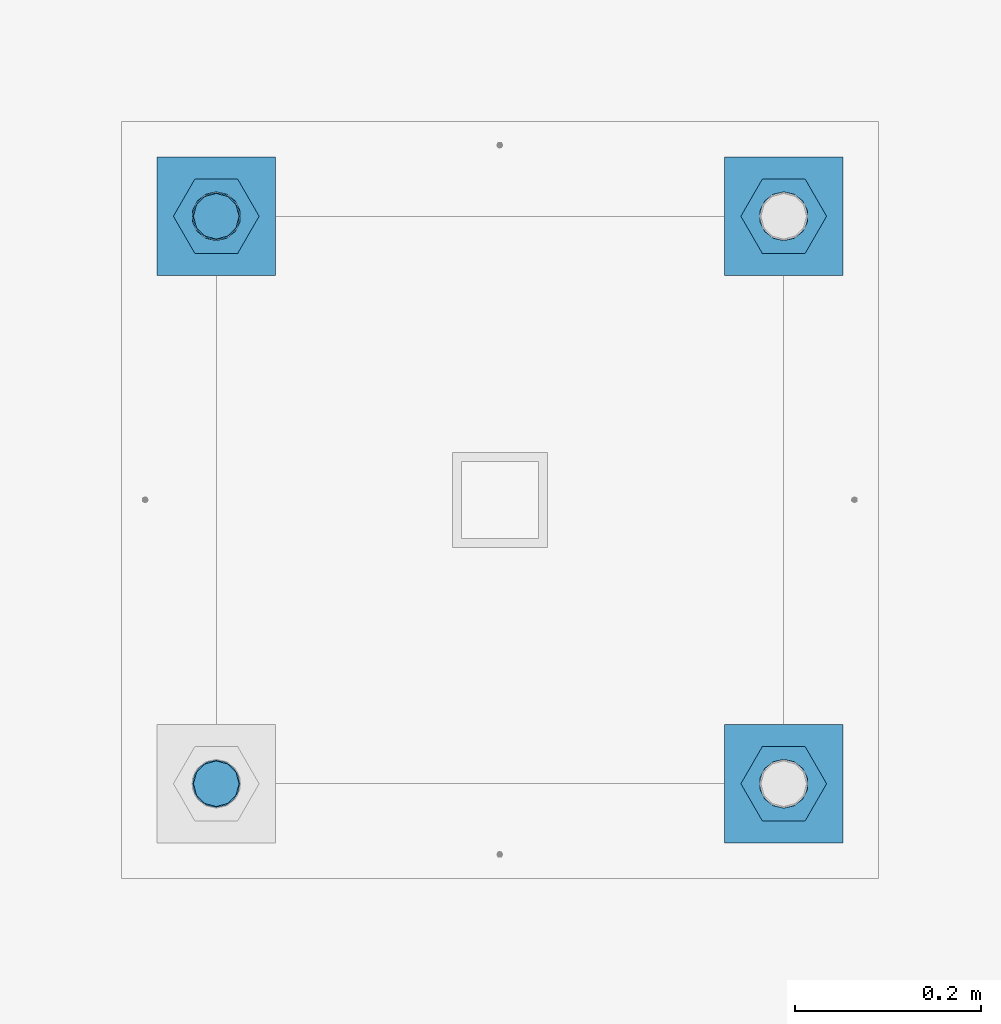
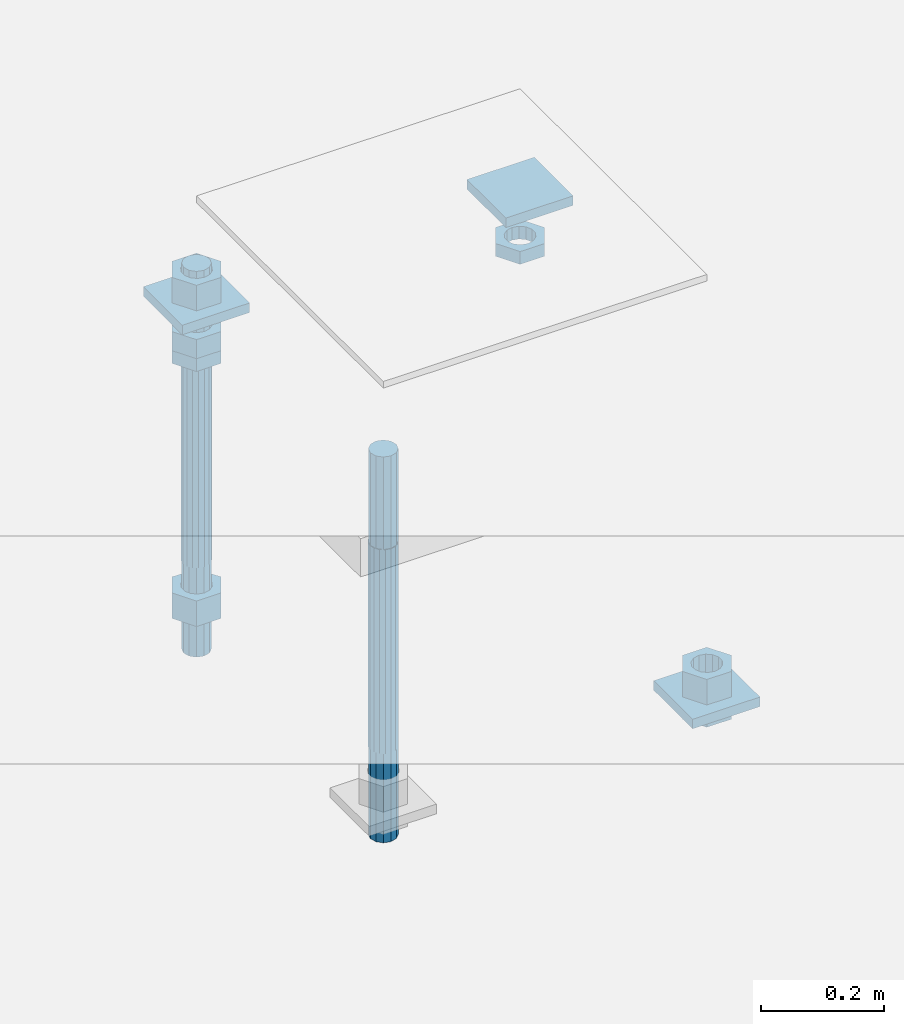
# One storey, part 2702 of 3843: 12 beams, 1 element without a shape of its own.
"""IFC2X3 building model written with IfcOpenShell, lengths in millimetres."""

from ifc_helpers import new_model, si_unit, frame, origin_with_axes, place, context, subcontext, project, spatial, faceted_brep, material, type_object, element, aggregate, save


model = new_model("IFC2X3")

# Units and contexts
model_context = context("Model", 3, precision=1e-05, world=origin_with_axes())
body_context = subcontext(model_context, "Body", "Model", "MODEL_VIEW")
ifc_project = project(units=[si_unit("LENGTHUNIT", "METRE", prefix="MILLI"), si_unit("AREAUNIT", "SQUARE_METRE"), si_unit("VOLUMEUNIT", "CUBIC_METRE"), si_unit("MASSUNIT", "GRAM", prefix="KILO"), si_unit("TIMEUNIT", "SECOND"), si_unit("PLANEANGLEUNIT", "RADIAN"), si_unit("SOLIDANGLEUNIT", "STERADIAN"), si_unit("THERMODYNAMICTEMPERATUREUNIT", "DEGREE_CELSIUS"), si_unit("LUMINOUSINTENSITYUNIT", "LUMEN")], contexts=[model_context])

# Site, building, storey
site_placement = place(None, origin_with_axes())
site = spatial("IfcSite", under=ifc_project, at=site_placement, CompositionType="ELEMENT")
building_placement = place(site_placement, origin_with_axes())
building = spatial("IfcBuilding", under=site, at=building_placement, Name="Undefined", CompositionType="ELEMENT")
storey_placement = place(building_placement, origin_with_axes())
storey = spatial("IfcBuildingStorey", under=building, at=storey_placement, Name="Undefined", CompositionType="ELEMENT", Elevation=0.0)

# Assembly, beams
assembly_placement = place(storey_placement, origin_with_axes())
assembly = element("IfcElementAssembly", 1, at=assembly_placement, inside=storey, Name="TEMPLATE", AssemblyPlace="NOTDEFINED", PredefinedType="RIGID_FRAME")
ifc_material_1 = material(Name="STEEL/A36")
beam_type_1 = type_object("IfcBeamType", PredefinedType="NOTDEFINED")
beam_1_placement = place(assembly_placement, frame((108648.5, 42113.2000015259, 29873.575), z_axis=(1.0, 0.0, 0.0), x_axis=(0.0, 1.0, 0.0)))
beam_1 = element("IfcBeam", 2, at=beam_1_placement, type_object=beam_type_1, material=ifc_material_1, Name="WASHER_PLATE", context=body_context, shape_type="Brep", body=[
    faceted_brep([(0.0, 9.52500000000146, -63.5), (0.0, 9.52500000000146, 63.5), (127.0, 9.52500000000146, 63.5), (127.0, 9.52500000000146, -63.5), (0.0, -9.52500000000146, 63.5), (127.0, -9.52500000000146, 63.5), (0.0, -9.52500000000146, -63.5), (127.0, -9.52500000000146, -63.5)], [[[0, 1, 2, 3]], [[1, 4, 5, 2]], [[4, 6, 7, 5]], [[6, 0, 3, 7]], [[5, 7, 3, 2]], [[6, 4, 1, 0]]]),
])
beam_2_placement = place(assembly_placement, frame((109258.1, 42113.2000015259, 29873.575), z_axis=(1.0, 0.0, 0.0), x_axis=(0.0, 1.0, 0.0)))
beam_2 = element("IfcBeam", 3, at=beam_2_placement, type_object=beam_type_1, material=ifc_material_1, Name="WASHER_PLATE", context=body_context, shape_type="Brep", body=[
    faceted_brep([(0.0, 9.52500000000146, -63.5), (0.0, 9.52500000000146, 63.5), (127.0, 9.52500000000146, 63.5), (127.0, 9.52500000000146, -63.5), (0.0, -9.52500000000146, 63.5), (127.0, -9.52500000000146, 63.5), (0.0, -9.52500000000146, -63.5), (127.0, -9.52500000000146, -63.5)], [[[0, 1, 2, 3]], [[1, 4, 5, 2]], [[4, 6, 7, 5]], [[6, 0, 3, 7]], [[5, 7, 3, 2]], [[6, 4, 1, 0]]]),
])
beam_3_placement = place(assembly_placement, frame((109258.1, 41503.6000015259, 29244.925), z_axis=(1.0, 0.0, 0.0), x_axis=(0.0, 1.0, 0.0)))
beam_3 = element("IfcBeam", 4, at=beam_3_placement, type_object=beam_type_1, material=ifc_material_1, Name="WASHER_PLATE", context=body_context, shape_type="Brep", body=[
    faceted_brep([(0.0, 9.52500000000146, -63.5), (0.0, 9.52500000000146, 63.5), (127.0, 9.52500000000146, 63.5), (127.0, 9.52500000000146, -63.5), (0.0, -9.52500000000146, 63.5), (127.0, -9.52500000000146, 63.5), (0.0, -9.52500000000146, -63.5), (127.0, -9.52500000000146, -63.5)], [[[0, 1, 2, 3]], [[1, 4, 5, 2]], [[4, 6, 7, 5]], [[6, 0, 3, 7]], [[5, 7, 3, 2]], [[6, 4, 1, 0]]]),
])
beam_type_2 = type_object("IfcBeamType", Name="2_HALF_NUT", PredefinedType="NOTDEFINED")
beam_4_placement = place(assembly_placement, frame((108648.5, 42176.7000015259, 29787.85), z_axis=(0.0, 1.0, 0.0), x_axis=(0.0, 0.0, -1.0)))
beam_4 = element("IfcBeam", 5, at=beam_4_placement, type_object=beam_type_2, material=ifc_material_1, Name="NUT", ObjectType="2_HALF_NUT", context=body_context, shape_type="Brep", body=[
    faceted_brep([(0.0, -46.0369987487793, 0.0), (0.0, -23.0184993743896, -39.869213104248), (25.4000000000015, -23.0184993743896, -39.869213104248), (25.4000000000015, -46.0369987487793, 0.0), (0.0, 23.0184993743896, -39.869213104248), (25.4000000000015, 23.0184993743896, -39.869213104248), (0.0, 46.0369987487793, 0.0), (25.4000000000015, 46.0369987487793, 0.0), (0.0, 23.0184993743896, 39.869213104248), (25.4000000000015, 23.0184993743896, 39.869213104248), (0.0, -23.0184993743896, 39.869213104248), (25.4000000000015, -23.0184993743896, 39.869213104248), (0.0, 0.0, 26.1940002441406), (0.0, 11.3650617044477, 23.5999013092805), (25.4000000000015, 11.3650617044477, 23.5999013092805), (25.4000000000015, 0.0, 26.1940002441406), (0.0, 20.4791109456419, 16.3316083006721), (25.4000000000015, 20.4791109456419, 16.3316083006721), (0.0, 25.5370200498292, 5.82867859874386), (25.4000000000015, 25.5370200498292, 5.82867859874386), (0.0, 25.5370200498292, -5.82867859874386), (25.4000000000015, 25.5370200498292, -5.82867859874386), (0.0, 20.4791109456419, -16.3316083006721), (25.4000000000015, 20.4791109456419, -16.3316083006721), (0.0, 11.3650617044477, -23.5999013092805), (25.4000000000015, 11.3650617044477, -23.5999013092805), (0.0, 0.0, -26.1940002441406), (25.4000000000015, 0.0, -26.1940002441406), (0.0, -11.3650617044477, -23.5999013092805), (25.4000000000015, -11.3650617044477, -23.5999013092805), (0.0, -20.4791109456419, -16.3316083006721), (25.4000000000015, -20.4791109456419, -16.3316083006721), (0.0, -25.5370200498292, -5.82867859874386), (25.4000000000015, -25.5370200498292, -5.82867859874386), (0.0, -25.5370200498292, 5.82867859874386), (25.4000000000015, -25.5370200498292, 5.82867859874386), (0.0, -20.4791109456419, 16.3316083006721), (25.4000000000015, -20.4791109456419, 16.3316083006721), (0.0, -11.3650617044477, 23.5999013092805), (25.4000000000015, -11.3650617044477, 23.5999013092805)], [[[0, 1, 2, 3]], [[1, 4, 5, 2]], [[4, 6, 7, 5]], [[6, 8, 9, 7]], [[8, 10, 11, 9]], [[10, 0, 3, 11]], [[12, 13, 14, 15]], [[13, 16, 17, 14]], [[16, 18, 19, 17]], [[18, 20, 21, 19]], [[20, 22, 23, 21]], [[22, 24, 25, 23]], [[24, 26, 27, 25]], [[26, 28, 29, 27]], [[28, 30, 31, 29]], [[30, 32, 33, 31]], [[32, 34, 35, 33]], [[34, 36, 37, 35]], [[36, 38, 39, 37]], [[38, 12, 15, 39]], [[5, 7, 9, 11, 3, 2], [17, 19, 21, 23, 25, 27, 29, 31, 33, 35, 37, 39, 15, 14]], [[10, 8, 6, 4, 1, 0], [38, 36, 34, 32, 30, 28, 26, 24, 22, 20, 18, 16, 13, 12]]]),
])
beam_5_placement = place(assembly_placement, frame((109258.1, 42176.7000015259, 29787.85), z_axis=(0.0, 1.0, 0.0), x_axis=(0.0, 0.0, -1.0)))
beam_5 = element("IfcBeam", 6, at=beam_5_placement, type_object=beam_type_2, material=ifc_material_1, Name="NUT", ObjectType="2_HALF_NUT", context=body_context, shape_type="Brep", body=[
    faceted_brep([(0.0, -46.0369987487793, 0.0), (0.0, -23.0184993743896, -39.869213104248), (25.4000000000015, -23.0184993743896, -39.869213104248), (25.4000000000015, -46.0369987487793, 0.0), (0.0, 23.0184993743896, -39.869213104248), (25.4000000000015, 23.0184993743896, -39.869213104248), (0.0, 46.0369987487793, 0.0), (25.4000000000015, 46.0369987487793, 0.0), (0.0, 23.0184993743896, 39.869213104248), (25.4000000000015, 23.0184993743896, 39.869213104248), (0.0, -23.0184993743896, 39.869213104248), (25.4000000000015, -23.0184993743896, 39.869213104248), (0.0, 0.0, 26.1940002441406), (0.0, 11.3650617044477, 23.5999013092805), (25.4000000000015, 11.3650617044477, 23.5999013092805), (25.4000000000015, 0.0, 26.1940002441406), (0.0, 20.4791109456419, 16.3316083006721), (25.4000000000015, 20.4791109456419, 16.3316083006721), (0.0, 25.5370200498292, 5.82867859874386), (25.4000000000015, 25.5370200498292, 5.82867859874386), (0.0, 25.5370200498292, -5.82867859874386), (25.4000000000015, 25.5370200498292, -5.82867859874386), (0.0, 20.4791109456419, -16.3316083006721), (25.4000000000015, 20.4791109456419, -16.3316083006721), (0.0, 11.3650617044477, -23.5999013092805), (25.4000000000015, 11.3650617044477, -23.5999013092805), (0.0, 0.0, -26.1940002441406), (25.4000000000015, 0.0, -26.1940002441406), (0.0, -11.3650617044477, -23.5999013092805), (25.4000000000015, -11.3650617044477, -23.5999013092805), (0.0, -20.4791109456419, -16.3316083006721), (25.4000000000015, -20.4791109456419, -16.3316083006721), (0.0, -25.5370200498292, -5.82867859874386), (25.4000000000015, -25.5370200498292, -5.82867859874386), (0.0, -25.5370200498292, 5.82867859874386), (25.4000000000015, -25.5370200498292, 5.82867859874386), (0.0, -20.4791109456419, 16.3316083006721), (25.4000000000015, -20.4791109456419, 16.3316083006721), (0.0, -11.3650617044477, 23.5999013092805), (25.4000000000015, -11.3650617044477, 23.5999013092805)], [[[0, 1, 2, 3]], [[1, 4, 5, 2]], [[4, 6, 7, 5]], [[6, 8, 9, 7]], [[8, 10, 11, 9]], [[10, 0, 3, 11]], [[12, 13, 14, 15]], [[13, 16, 17, 14]], [[16, 18, 19, 17]], [[18, 20, 21, 19]], [[20, 22, 23, 21]], [[22, 24, 25, 23]], [[24, 26, 27, 25]], [[26, 28, 29, 27]], [[28, 30, 31, 29]], [[30, 32, 33, 31]], [[32, 34, 35, 33]], [[34, 36, 37, 35]], [[36, 38, 39, 37]], [[38, 12, 15, 39]], [[5, 7, 9, 11, 3, 2], [17, 19, 21, 23, 25, 27, 29, 31, 33, 35, 37, 39, 15, 14]], [[10, 8, 6, 4, 1, 0], [38, 36, 34, 32, 30, 28, 26, 24, 22, 20, 18, 16, 13, 12]]]),
])
beam_6_placement = place(assembly_placement, frame((109258.1, 41567.1000015259, 29235.4), z_axis=(0.0, 1.0, 0.0), x_axis=(0.0, 0.0, -1.0)))
beam_6 = element("IfcBeam", 7, at=beam_6_placement, type_object=beam_type_2, material=ifc_material_1, Name="NUT", ObjectType="2_HALF_NUT", context=body_context, shape_type="Brep", body=[
    faceted_brep([(0.0, -46.0369987487793, 0.0), (0.0, -23.0184993743896, -39.869213104248), (25.4000000000015, -23.0184993743896, -39.869213104248), (25.4000000000015, -46.0369987487793, 0.0), (0.0, 23.0184993743896, -39.869213104248), (25.4000000000015, 23.0184993743896, -39.869213104248), (0.0, 46.0369987487793, 0.0), (25.4000000000015, 46.0369987487793, 0.0), (0.0, 23.0184993743896, 39.869213104248), (25.4000000000015, 23.0184993743896, 39.869213104248), (0.0, -23.0184993743896, 39.869213104248), (25.4000000000015, -23.0184993743896, 39.869213104248), (0.0, 0.0, 26.1940002441406), (0.0, 11.3650617044477, 23.5999013092805), (25.4000000000015, 11.3650617044477, 23.5999013092805), (25.4000000000015, 0.0, 26.1940002441406), (0.0, 20.4791109456419, 16.3316083006721), (25.4000000000015, 20.4791109456419, 16.3316083006721), (0.0, 25.5370200498292, 5.82867859874386), (25.4000000000015, 25.5370200498292, 5.82867859874386), (0.0, 25.5370200498292, -5.82867859874386), (25.4000000000015, 25.5370200498292, -5.82867859874386), (0.0, 20.4791109456419, -16.3316083006721), (25.4000000000015, 20.4791109456419, -16.3316083006721), (0.0, 11.3650617044477, -23.5999013092805), (25.4000000000015, 11.3650617044477, -23.5999013092805), (0.0, 0.0, -26.1940002441406), (25.4000000000015, 0.0, -26.1940002441406), (0.0, -11.3650617044477, -23.5999013092805), (25.4000000000015, -11.3650617044477, -23.5999013092805), (0.0, -20.4791109456419, -16.3316083006721), (25.4000000000015, -20.4791109456419, -16.3316083006721), (0.0, -25.5370200498292, -5.82867859874386), (25.4000000000015, -25.5370200498292, -5.82867859874386), (0.0, -25.5370200498292, 5.82867859874386), (25.4000000000015, -25.5370200498292, 5.82867859874386), (0.0, -20.4791109456419, 16.3316083006721), (25.4000000000015, -20.4791109456419, 16.3316083006721), (0.0, -11.3650617044477, 23.5999013092805), (25.4000000000015, -11.3650617044477, 23.5999013092805)], [[[0, 1, 2, 3]], [[1, 4, 5, 2]], [[4, 6, 7, 5]], [[6, 8, 9, 7]], [[8, 10, 11, 9]], [[10, 0, 3, 11]], [[12, 13, 14, 15]], [[13, 16, 17, 14]], [[16, 18, 19, 17]], [[18, 20, 21, 19]], [[20, 22, 23, 21]], [[22, 24, 25, 23]], [[24, 26, 27, 25]], [[26, 28, 29, 27]], [[28, 30, 31, 29]], [[30, 32, 33, 31]], [[32, 34, 35, 33]], [[34, 36, 37, 35]], [[36, 38, 39, 37]], [[38, 12, 15, 39]], [[5, 7, 9, 11, 3, 2], [17, 19, 21, 23, 25, 27, 29, 31, 33, 35, 37, 39, 15, 14]], [[10, 8, 6, 4, 1, 0], [38, 36, 34, 32, 30, 28, 26, 24, 22, 20, 18, 16, 13, 12]]]),
])
beam_type_3 = type_object("IfcBeamType", Name="2_HEAVY_HEX_NUT", PredefinedType="NOTDEFINED")
beam_7_placement = place(assembly_placement, frame((109258.1, 41567.1000015259, 29305.25), z_axis=(0.0, 1.0, 0.0), x_axis=(0.0, 0.0, -1.0)))
beam_7 = element("IfcBeam", 8, at=beam_7_placement, type_object=beam_type_3, material=ifc_material_1, Name="NUT", ObjectType="2_HEAVY_HEX_NUT", context=body_context, shape_type="Brep", body=[
    faceted_brep([(0.0, -46.0369987487793, 0.0), (0.0, -23.0184993743896, -39.869213104248), (50.7999999999993, -23.0184993743896, -39.869213104248), (50.7999999999993, -46.0369987487793, 0.0), (0.0, 23.0184993743896, -39.869213104248), (50.7999999999993, 23.0184993743896, -39.869213104248), (0.0, 46.0369987487793, 0.0), (50.7999999999993, 46.0369987487793, 0.0), (0.0, 23.0184993743896, 39.869213104248), (50.7999999999993, 23.0184993743896, 39.869213104248), (0.0, -23.0184993743896, 39.869213104248), (50.7999999999993, -23.0184993743896, 39.869213104248), (0.0, 0.0, 26.1940002441406), (0.0, 11.3650617044477, 23.5999013092805), (50.7999999999993, 11.3650617044477, 23.5999013092805), (50.7999999999993, 0.0, 26.1940002441406), (0.0, 20.4791109456419, 16.3316083006721), (50.7999999999993, 20.4791109456419, 16.3316083006721), (0.0, 25.5370200498292, 5.82867859874386), (50.7999999999993, 25.5370200498292, 5.82867859874386), (0.0, 25.5370200498292, -5.82867859874386), (50.7999999999993, 25.5370200498292, -5.82867859874386), (0.0, 20.4791109456419, -16.3316083006721), (50.7999999999993, 20.4791109456419, -16.3316083006721), (0.0, 11.3650617044477, -23.5999013092805), (50.7999999999993, 11.3650617044477, -23.5999013092805), (0.0, 0.0, -26.1940002441406), (50.7999999999993, 0.0, -26.1940002441406), (0.0, -11.3650617044477, -23.5999013092805), (50.7999999999993, -11.3650617044477, -23.5999013092805), (0.0, -20.4791109456419, -16.3316083006721), (50.7999999999993, -20.4791109456419, -16.3316083006721), (0.0, -25.5370200498292, -5.82867859874386), (50.7999999999993, -25.5370200498292, -5.82867859874386), (0.0, -25.5370200498292, 5.82867859874386), (50.7999999999993, -25.5370200498292, 5.82867859874386), (0.0, -20.4791109456419, 16.3316083006721), (50.7999999999993, -20.4791109456419, 16.3316083006721), (0.0, -11.3650617044477, 23.5999013092805), (50.7999999999993, -11.3650617044477, 23.5999013092805)], [[[0, 1, 2, 3]], [[1, 4, 5, 2]], [[4, 6, 7, 5]], [[6, 8, 9, 7]], [[8, 10, 11, 9]], [[10, 0, 3, 11]], [[12, 13, 14, 15]], [[13, 16, 17, 14]], [[16, 18, 19, 17]], [[18, 20, 21, 19]], [[20, 22, 23, 21]], [[22, 24, 25, 23]], [[24, 26, 27, 25]], [[26, 28, 29, 27]], [[28, 30, 31, 29]], [[30, 32, 33, 31]], [[32, 34, 35, 33]], [[34, 36, 37, 35]], [[36, 38, 39, 37]], [[38, 12, 15, 39]], [[5, 7, 9, 11, 3, 2], [17, 19, 21, 23, 25, 27, 29, 31, 33, 35, 37, 39, 15, 14]], [[10, 8, 6, 4, 1, 0], [38, 36, 34, 32, 30, 28, 26, 24, 22, 20, 18, 16, 13, 12]]]),
])
beam_8_placement = place(assembly_placement, frame((108648.5, 42176.7000015259, 29825.95), z_axis=(0.0, 1.0, 0.0), x_axis=(0.0, 0.0, -1.0)))
beam_8 = element("IfcBeam", 9, at=beam_8_placement, type_object=beam_type_3, material=ifc_material_1, Name="NUT", ObjectType="2_HEAVY_HEX_NUT", context=body_context, shape_type="Brep", body=[
    faceted_brep([(0.0, -46.0369987487793, 0.0), (0.0, -23.0184993743896, -39.869213104248), (38.0999999999985, -23.0184993743896, -39.869213104248), (38.0999999999985, -46.0369987487793, 0.0), (0.0, 23.0184993743896, -39.869213104248), (38.0999999999985, 23.0184993743896, -39.869213104248), (0.0, 46.0369987487793, 0.0), (38.0999999999985, 46.0369987487793, 0.0), (0.0, 23.0184993743896, 39.869213104248), (38.0999999999985, 23.0184993743896, 39.869213104248), (0.0, -23.0184993743896, 39.869213104248), (38.0999999999985, -23.0184993743896, 39.869213104248), (0.0, 0.0, 26.1940002441406), (0.0, 11.3650617044477, 23.5999013092805), (38.0999999999985, 11.3650617044477, 23.5999013092805), (38.0999999999985, 0.0, 26.1940002441406), (0.0, 20.4791109456419, 16.3316083006721), (38.0999999999985, 20.4791109456419, 16.3316083006721), (0.0, 25.5370200498292, 5.82867859874386), (38.0999999999985, 25.5370200498292, 5.82867859874386), (0.0, 25.5370200498292, -5.82867859874386), (38.0999999999985, 25.5370200498292, -5.82867859874386), (0.0, 20.4791109456419, -16.3316083006721), (38.0999999999985, 20.4791109456419, -16.3316083006721), (0.0, 11.3650617044477, -23.5999013092805), (38.0999999999985, 11.3650617044477, -23.5999013092805), (0.0, 0.0, -26.1940002441406), (38.0999999999985, 0.0, -26.1940002441406), (0.0, -11.3650617044477, -23.5999013092805), (38.0999999999985, -11.3650617044477, -23.5999013092805), (0.0, -20.4791109456419, -16.3316083006721), (38.0999999999985, -20.4791109456419, -16.3316083006721), (0.0, -25.5370200498292, -5.82867859874386), (38.0999999999985, -25.5370200498292, -5.82867859874386), (0.0, -25.5370200498292, 5.82867859874386), (38.0999999999985, -25.5370200498292, 5.82867859874386), (0.0, -20.4791109456419, 16.3316083006721), (38.0999999999985, -20.4791109456419, 16.3316083006721), (0.0, -11.3650617044477, 23.5999013092805), (38.0999999999985, -11.3650617044477, 23.5999013092805)], [[[0, 1, 2, 3]], [[1, 4, 5, 2]], [[4, 6, 7, 5]], [[6, 8, 9, 7]], [[8, 10, 11, 9]], [[10, 0, 3, 11]], [[12, 13, 14, 15]], [[13, 16, 17, 14]], [[16, 18, 19, 17]], [[18, 20, 21, 19]], [[20, 22, 23, 21]], [[22, 24, 25, 23]], [[24, 26, 27, 25]], [[26, 28, 29, 27]], [[28, 30, 31, 29]], [[30, 32, 33, 31]], [[32, 34, 35, 33]], [[34, 36, 37, 35]], [[36, 38, 39, 37]], [[38, 12, 15, 39]], [[5, 7, 9, 11, 3, 2], [17, 19, 21, 23, 25, 27, 29, 31, 33, 35, 37, 39, 15, 14]], [[10, 8, 6, 4, 1, 0], [38, 36, 34, 32, 30, 28, 26, 24, 22, 20, 18, 16, 13, 12]]]),
])
beam_9_placement = place(assembly_placement, frame((108648.5, 42176.7000015259, 29933.9), z_axis=(0.0, 1.0, 0.0), x_axis=(0.0, 0.0, -1.0)))
beam_9 = element("IfcBeam", 10, at=beam_9_placement, type_object=beam_type_3, material=ifc_material_1, Name="NUT", ObjectType="2_HEAVY_HEX_NUT", context=body_context, shape_type="Brep", body=[
    faceted_brep([(0.0, -46.0369987487793, 0.0), (0.0, -23.0184993743896, -39.869213104248), (50.7999999999993, -23.0184993743896, -39.869213104248), (50.7999999999993, -46.0369987487793, 0.0), (0.0, 23.0184993743896, -39.869213104248), (50.7999999999993, 23.0184993743896, -39.869213104248), (0.0, 46.0369987487793, 0.0), (50.7999999999993, 46.0369987487793, 0.0), (0.0, 23.0184993743896, 39.869213104248), (50.7999999999993, 23.0184993743896, 39.869213104248), (0.0, -23.0184993743896, 39.869213104248), (50.7999999999993, -23.0184993743896, 39.869213104248), (0.0, 0.0, 26.1940002441406), (0.0, 11.3650617044477, 23.5999013092805), (50.7999999999993, 11.3650617044477, 23.5999013092805), (50.7999999999993, 0.0, 26.1940002441406), (0.0, 20.4791109456419, 16.3316083006721), (50.7999999999993, 20.4791109456419, 16.3316083006721), (0.0, 25.5370200498292, 5.82867859874386), (50.7999999999993, 25.5370200498292, 5.82867859874386), (0.0, 25.5370200498292, -5.82867859874386), (50.7999999999993, 25.5370200498292, -5.82867859874386), (0.0, 20.4791109456419, -16.3316083006721), (50.7999999999993, 20.4791109456419, -16.3316083006721), (0.0, 11.3650617044477, -23.5999013092805), (50.7999999999993, 11.3650617044477, -23.5999013092805), (0.0, 0.0, -26.1940002441406), (50.7999999999993, 0.0, -26.1940002441406), (0.0, -11.3650617044477, -23.5999013092805), (50.7999999999993, -11.3650617044477, -23.5999013092805), (0.0, -20.4791109456419, -16.3316083006721), (50.7999999999993, -20.4791109456419, -16.3316083006721), (0.0, -25.5370200498292, -5.82867859874386), (50.7999999999993, -25.5370200498292, -5.82867859874386), (0.0, -25.5370200498292, 5.82867859874386), (50.7999999999993, -25.5370200498292, 5.82867859874386), (0.0, -20.4791109456419, 16.3316083006721), (50.7999999999993, -20.4791109456419, 16.3316083006721), (0.0, -11.3650617044477, 23.5999013092805), (50.7999999999993, -11.3650617044477, 23.5999013092805)], [[[0, 1, 2, 3]], [[1, 4, 5, 2]], [[4, 6, 7, 5]], [[6, 8, 9, 7]], [[8, 10, 11, 9]], [[10, 0, 3, 11]], [[12, 13, 14, 15]], [[13, 16, 17, 14]], [[16, 18, 19, 17]], [[18, 20, 21, 19]], [[20, 22, 23, 21]], [[22, 24, 25, 23]], [[24, 26, 27, 25]], [[26, 28, 29, 27]], [[28, 30, 31, 29]], [[30, 32, 33, 31]], [[32, 34, 35, 33]], [[34, 36, 37, 35]], [[36, 38, 39, 37]], [[38, 12, 15, 39]], [[5, 7, 9, 11, 3, 2], [17, 19, 21, 23, 25, 27, 29, 31, 33, 35, 37, 39, 15, 14]], [[10, 8, 6, 4, 1, 0], [38, 36, 34, 32, 30, 28, 26, 24, 22, 20, 18, 16, 13, 12]]]),
])
beam_10_placement = place(assembly_placement, frame((108648.5, 42176.7000015259, 29305.25), z_axis=(0.0, 1.0, 0.0), x_axis=(0.0, 0.0, -1.0)))
beam_10 = element("IfcBeam", 11, at=beam_10_placement, type_object=beam_type_3, material=ifc_material_1, Name="NUT", ObjectType="2_HEAVY_HEX_NUT", context=body_context, shape_type="Brep", body=[
    faceted_brep([(0.0, -46.0369987487793, 0.0), (0.0, -23.0184993743896, -39.869213104248), (50.7999999999993, -23.0184993743896, -39.869213104248), (50.7999999999993, -46.0369987487793, 0.0), (0.0, 23.0184993743896, -39.869213104248), (50.7999999999993, 23.0184993743896, -39.869213104248), (0.0, 46.0369987487793, 0.0), (50.7999999999993, 46.0369987487793, 0.0), (0.0, 23.0184993743896, 39.869213104248), (50.7999999999993, 23.0184993743896, 39.869213104248), (0.0, -23.0184993743896, 39.869213104248), (50.7999999999993, -23.0184993743896, 39.869213104248), (0.0, 0.0, 26.1940002441406), (0.0, 11.3650617044477, 23.5999013092805), (50.7999999999993, 11.3650617044477, 23.5999013092805), (50.7999999999993, 0.0, 26.1940002441406), (0.0, 20.4791109456419, 16.3316083006721), (50.7999999999993, 20.4791109456419, 16.3316083006721), (0.0, 25.5370200498292, 5.82867859874386), (50.7999999999993, 25.5370200498292, 5.82867859874386), (0.0, 25.5370200498292, -5.82867859874386), (50.7999999999993, 25.5370200498292, -5.82867859874386), (0.0, 20.4791109456419, -16.3316083006721), (50.7999999999993, 20.4791109456419, -16.3316083006721), (0.0, 11.3650617044477, -23.5999013092805), (50.7999999999993, 11.3650617044477, -23.5999013092805), (0.0, 0.0, -26.1940002441406), (50.7999999999993, 0.0, -26.1940002441406), (0.0, -11.3650617044477, -23.5999013092805), (50.7999999999993, -11.3650617044477, -23.5999013092805), (0.0, -20.4791109456419, -16.3316083006721), (50.7999999999993, -20.4791109456419, -16.3316083006721), (0.0, -25.5370200498292, -5.82867859874386), (50.7999999999993, -25.5370200498292, -5.82867859874386), (0.0, -25.5370200498292, 5.82867859874386), (50.7999999999993, -25.5370200498292, 5.82867859874386), (0.0, -20.4791109456419, 16.3316083006721), (50.7999999999993, -20.4791109456419, 16.3316083006721), (0.0, -11.3650617044477, 23.5999013092805), (50.7999999999993, -11.3650617044477, 23.5999013092805)], [[[0, 1, 2, 3]], [[1, 4, 5, 2]], [[4, 6, 7, 5]], [[6, 8, 9, 7]], [[8, 10, 11, 9]], [[10, 0, 3, 11]], [[12, 13, 14, 15]], [[13, 16, 17, 14]], [[16, 18, 19, 17]], [[18, 20, 21, 19]], [[20, 22, 23, 21]], [[22, 24, 25, 23]], [[24, 26, 27, 25]], [[26, 28, 29, 27]], [[28, 30, 31, 29]], [[30, 32, 33, 31]], [[32, 34, 35, 33]], [[34, 36, 37, 35]], [[36, 38, 39, 37]], [[38, 12, 15, 39]], [[5, 7, 9, 11, 3, 2], [17, 19, 21, 23, 25, 27, 29, 31, 33, 35, 37, 39, 15, 14]], [[10, 8, 6, 4, 1, 0], [38, 36, 34, 32, 30, 28, 26, 24, 22, 20, 18, 16, 13, 12]]]),
])
ifc_material_2 = material()
beam_type_4 = type_object("IfcBeamType", PredefinedType="NOTDEFINED")
beam_11_placement = place(assembly_placement, frame((108648.5, 42176.7000015259, 29762.45), z_axis=(0.0, 1.0, 0.0), x_axis=(0.0, 0.0, -1.0)))
beam_11 = element("IfcBeam", 12, at=beam_11_placement, type_object=beam_type_4, material=ifc_material_2, Name="ANCHOR_ROD", context=body_context, shape_type="Brep", body=[
    faceted_brep([(-184.150000000001, -21.217622392709, 12.25), (-184.150000000001, -12.2499999999854, 21.2176223927163), (-184.150000000001, 1.45519152283669e-11, 24.5), (-184.150000000001, 12.2500000000146, 21.2176223927163), (-184.150000000001, 21.2176223927381, 12.25), (-184.150000000001, 24.5000000000146, 0.0), (-184.150000000001, 21.2176223927381, -12.25), (-184.150000000001, 12.2500000000146, -21.2176223927163), (-184.150000000001, 1.45519152283669e-11, -24.5), (-184.150000000001, -12.2499999999854, -21.2176223927163), (-184.150000000001, -21.217622392709, -12.25), (-184.150000000001, -24.4999999999854, 0.0), (0.0, 24.5000000000146, 0.0), (0.0, 21.2176223927381, -12.25), (0.0, 12.2500000000146, -21.2176223927163), (0.0, 1.45519152283669e-11, -24.5), (0.0, -12.2499999999854, -21.2176223927163), (0.0, -21.217622392709, -12.25), (0.0, -24.4999999999854, 0.0), (0.0, -21.217622392709, 12.25), (0.0, -12.2499999999854, 21.2176223927163), (0.0, 1.45519152283669e-11, 24.5), (0.0, 12.2500000000146, 21.2176223927163), (0.0, 21.2176223927381, 12.25), (0.0, -23.4665401257807, 9.72015918207035), (0.0, -17.9605122421344, 17.9605122421417), (0.0, -9.72015918207762, 23.466540125788), (0.0, 0.0, 25.4000000000015), (0.0, 9.72015918207762, 23.466540125788), (0.0, 17.9605122421344, 17.9605122421417), (0.0, 23.4665401257807, 9.72015918207035), (0.0, 25.3999996185303, 0.0), (0.0, 23.4665401257807, -9.72015918207035), (0.0, 17.9605122421344, -17.9605122421417), (0.0, 9.72015918207762, -23.466540125788), (0.0, 0.0, -25.4000000000015), (0.0, -9.72015918207762, -23.466540125788), (0.0, -17.9605122421344, -17.9605122421417), (0.0, -23.4665401257807, -9.72015918207035), (0.0, -25.3999996185303, 0.0), (406.399999999998, -25.3999999999942, 0.0), (406.399999999998, -23.4665401257807, 9.72015918207035), (406.399999999998, -17.9605122421344, 17.9605122421417), (406.399999999998, -9.72015918207762, 23.466540125788), (406.399999999998, 0.0, 25.4000000000015), (406.399999999998, 9.72015918207762, 23.466540125788), (406.399999999998, 17.9605122421344, 17.9605122421417), (406.399999999998, 23.4665401257807, 9.72015918207035), (406.399999999998, 25.3999999999942, 0.0), (406.399999999998, 23.4665401257807, -9.72015918207035), (406.399999999998, 17.9605122421344, -17.9605122421417), (406.399999999998, 9.72015918207762, -23.466540125788), (406.399999999998, 0.0, -25.4000000000015), (406.399999999998, -9.72015918207762, -23.466540125788), (406.399999999998, -17.9605122421344, -17.9605122421417), (406.399999999998, -23.4665401257807, -9.72015918207035), (406.399999999998, -12.2499999999854, 21.2176223927163), (406.399999999998, 1.45519152283669e-11, 24.5), (406.399999999998, 12.2500000000146, 21.2176223927163), (406.399999999998, 21.2176223927381, 12.25), (406.399999999998, 24.5000000000146, 0.0), (406.399999999998, 21.2176223927381, -12.25), (406.399999999998, 12.2500000000146, -21.2176223927163), (406.399999999998, 1.45519152283669e-11, -24.5), (406.399999999998, -12.2499999999854, -21.2176223927163), (406.399999999998, -21.217622392709, -12.25), (406.399999999998, -24.4999999999854, 0.0), (406.399999999998, -21.217622392709, 12.25), (584.200000000001, -12.2499999999854, -21.2176223927163), (584.200000000001, 1.45519152283669e-11, -24.5), (584.200000000001, 12.2500000000146, -21.2176223927163), (584.200000000001, 21.2176223927381, -12.25), (584.200000000001, 24.5000000000146, 0.0), (584.200000000001, 21.2176223927381, 12.25), (584.200000000001, 12.2500000000146, 21.2176223927163), (584.200000000001, 1.45519152283669e-11, 24.5), (584.200000000001, -12.2499999999854, 21.2176223927163), (584.200000000001, -21.217622392709, 12.25), (584.200000000001, -24.4999999999854, 0.0), (584.200000000001, -21.217622392709, -12.25)], [[[0, 1, 2, 3, 4, 5, 6, 7, 8, 9, 10, 11]], [[6, 5, 12, 13]], [[7, 6, 13, 14]], [[8, 7, 14, 15]], [[9, 8, 15, 16]], [[10, 9, 16, 17]], [[11, 10, 17, 18]], [[0, 11, 18, 19]], [[1, 0, 19, 20]], [[2, 1, 20, 21]], [[3, 2, 21, 22]], [[4, 3, 22, 23]], [[5, 4, 23, 12]], [[24, 25, 26, 27, 28, 29, 30, 31, 32, 33, 34, 35, 36, 37, 38, 39], [22, 21, 20, 19, 18, 17, 16, 15, 14, 13, 12, 23]], [[24, 39, 40, 41]], [[25, 24, 41, 42]], [[26, 25, 42, 43]], [[27, 26, 43, 44]], [[28, 27, 44, 45]], [[29, 28, 45, 46]], [[30, 29, 46, 47]], [[31, 30, 47, 48]], [[32, 31, 48, 49]], [[33, 32, 49, 50]], [[34, 33, 50, 51]], [[35, 34, 51, 52]], [[36, 35, 52, 53]], [[37, 36, 53, 54]], [[38, 37, 54, 55]], [[39, 38, 55, 40]], [[54, 53, 52, 51, 50, 49, 48, 47, 46, 45, 44, 43, 42, 41, 40, 55], [56, 57, 58, 59, 60, 61, 62, 63, 64, 65, 66, 67]], [[68, 69, 70, 71, 72, 73, 74, 75, 76, 77, 78, 79]], [[76, 75, 57, 56]], [[77, 76, 56, 67]], [[78, 77, 67, 66]], [[79, 78, 66, 65]], [[68, 79, 65, 64]], [[69, 68, 64, 63]], [[70, 69, 63, 62]], [[71, 70, 62, 61]], [[72, 71, 61, 60]], [[73, 72, 60, 59]], [[74, 73, 59, 58]], [[75, 74, 58, 57]]]),
])
beam_12_placement = place(assembly_placement, frame((108648.5, 41567.1000015259, 29762.45), z_axis=(0.0, 1.0, 0.0), x_axis=(0.0, 0.0, -1.0)))
beam_12 = element("IfcBeam", 13, at=beam_12_placement, type_object=beam_type_4, material=ifc_material_2, Name="ANCHOR_ROD", context=body_context, shape_type="Brep", body=[
    faceted_brep([(-184.150000000001, -21.217622392709, 12.25), (-184.150000000001, -12.2499999999854, 21.2176223927163), (-184.150000000001, 1.45519152283669e-11, 24.5), (-184.150000000001, 12.2500000000146, 21.2176223927163), (-184.150000000001, 21.2176223927381, 12.25), (-184.150000000001, 24.5000000000146, 0.0), (-184.150000000001, 21.2176223927381, -12.25), (-184.150000000001, 12.2500000000146, -21.2176223927163), (-184.150000000001, 1.45519152283669e-11, -24.5), (-184.150000000001, -12.2499999999854, -21.2176223927163), (-184.150000000001, -21.217622392709, -12.25), (-184.150000000001, -24.4999999999854, 0.0), (0.0, 24.5000000000146, 0.0), (0.0, 21.2176223927381, -12.25), (0.0, 12.2500000000146, -21.2176223927163), (0.0, 1.45519152283669e-11, -24.5), (0.0, -12.2499999999854, -21.2176223927163), (0.0, -21.217622392709, -12.25), (0.0, -24.4999999999854, 0.0), (0.0, -21.217622392709, 12.25), (0.0, -12.2499999999854, 21.2176223927163), (0.0, 1.45519152283669e-11, 24.5), (0.0, 12.2500000000146, 21.2176223927163), (0.0, 21.2176223927381, 12.25), (0.0, -23.4665401257807, 9.72015918207035), (0.0, -17.9605122421344, 17.9605122421417), (0.0, -9.72015918207762, 23.466540125788), (0.0, 0.0, 25.4000000000015), (0.0, 9.72015918207762, 23.466540125788), (0.0, 17.9605122421344, 17.9605122421417), (0.0, 23.4665401257807, 9.72015918207035), (0.0, 25.3999996185303, 0.0), (0.0, 23.4665401257807, -9.72015918207035), (0.0, 17.9605122421344, -17.9605122421417), (0.0, 9.72015918207762, -23.466540125788), (0.0, 0.0, -25.4000000000015), (0.0, -9.72015918207762, -23.466540125788), (0.0, -17.9605122421344, -17.9605122421417), (0.0, -23.4665401257807, -9.72015918207035), (0.0, -25.3999996185303, 0.0), (406.399999999998, -25.3999999999942, 0.0), (406.399999999998, -23.4665401257807, 9.72015918207035), (406.399999999998, -17.9605122421344, 17.9605122421417), (406.399999999998, -9.72015918207762, 23.466540125788), (406.399999999998, 0.0, 25.4000000000015), (406.399999999998, 9.72015918207762, 23.466540125788), (406.399999999998, 17.9605122421344, 17.9605122421417), (406.399999999998, 23.4665401257807, 9.72015918207035), (406.399999999998, 25.3999999999942, 0.0), (406.399999999998, 23.4665401257807, -9.72015918207035), (406.399999999998, 17.9605122421344, -17.9605122421417), (406.399999999998, 9.72015918207762, -23.466540125788), (406.399999999998, 0.0, -25.4000000000015), (406.399999999998, -9.72015918207762, -23.466540125788), (406.399999999998, -17.9605122421344, -17.9605122421417), (406.399999999998, -23.4665401257807, -9.72015918207035), (406.399999999998, -12.2499999999854, 21.2176223927163), (406.399999999998, 1.45519152283669e-11, 24.5), (406.399999999998, 12.2500000000146, 21.2176223927163), (406.399999999998, 21.2176223927381, 12.25), (406.399999999998, 24.5000000000146, 0.0), (406.399999999998, 21.2176223927381, -12.25), (406.399999999998, 12.2500000000146, -21.2176223927163), (406.399999999998, 1.45519152283669e-11, -24.5), (406.399999999998, -12.2499999999854, -21.2176223927163), (406.399999999998, -21.217622392709, -12.25), (406.399999999998, -24.4999999999854, 0.0), (406.399999999998, -21.217622392709, 12.25), (584.200000000001, -12.2499999999854, -21.2176223927163), (584.200000000001, 1.45519152283669e-11, -24.5), (584.200000000001, 12.2500000000146, -21.2176223927163), (584.200000000001, 21.2176223927381, -12.25), (584.200000000001, 24.5000000000146, 0.0), (584.200000000001, 21.2176223927381, 12.25), (584.200000000001, 12.2500000000146, 21.2176223927163), (584.200000000001, 1.45519152283669e-11, 24.5), (584.200000000001, -12.2499999999854, 21.2176223927163), (584.200000000001, -21.217622392709, 12.25), (584.200000000001, -24.4999999999854, 0.0), (584.200000000001, -21.217622392709, -12.25)], [[[0, 1, 2, 3, 4, 5, 6, 7, 8, 9, 10, 11]], [[6, 5, 12, 13]], [[7, 6, 13, 14]], [[8, 7, 14, 15]], [[9, 8, 15, 16]], [[10, 9, 16, 17]], [[11, 10, 17, 18]], [[0, 11, 18, 19]], [[1, 0, 19, 20]], [[2, 1, 20, 21]], [[3, 2, 21, 22]], [[4, 3, 22, 23]], [[5, 4, 23, 12]], [[24, 25, 26, 27, 28, 29, 30, 31, 32, 33, 34, 35, 36, 37, 38, 39], [22, 21, 20, 19, 18, 17, 16, 15, 14, 13, 12, 23]], [[24, 39, 40, 41]], [[25, 24, 41, 42]], [[26, 25, 42, 43]], [[27, 26, 43, 44]], [[28, 27, 44, 45]], [[29, 28, 45, 46]], [[30, 29, 46, 47]], [[31, 30, 47, 48]], [[32, 31, 48, 49]], [[33, 32, 49, 50]], [[34, 33, 50, 51]], [[35, 34, 51, 52]], [[36, 35, 52, 53]], [[37, 36, 53, 54]], [[38, 37, 54, 55]], [[39, 38, 55, 40]], [[54, 53, 52, 51, 50, 49, 48, 47, 46, 45, 44, 43, 42, 41, 40, 55], [56, 57, 58, 59, 60, 61, 62, 63, 64, 65, 66, 67]], [[68, 69, 70, 71, 72, 73, 74, 75, 76, 77, 78, 79]], [[76, 75, 57, 56]], [[77, 76, 56, 67]], [[78, 77, 67, 66]], [[79, 78, 66, 65]], [[68, 79, 65, 64]], [[69, 68, 64, 63]], [[70, 69, 63, 62]], [[71, 70, 62, 61]], [[72, 71, 61, 60]], [[73, 72, 60, 59]], [[74, 73, 59, 58]], [[75, 74, 58, 57]]]),
])
aggregate(assembly, [beam_4, beam_5, beam_1, beam_2, beam_7, beam_6, beam_3, beam_11, beam_8, beam_9, beam_10, beam_12])

save(model, "model.ifc")
